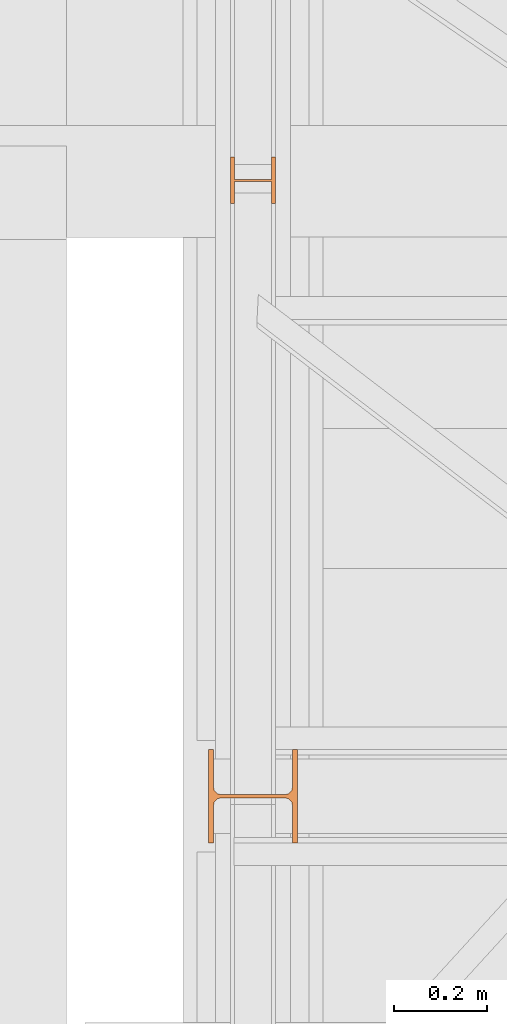
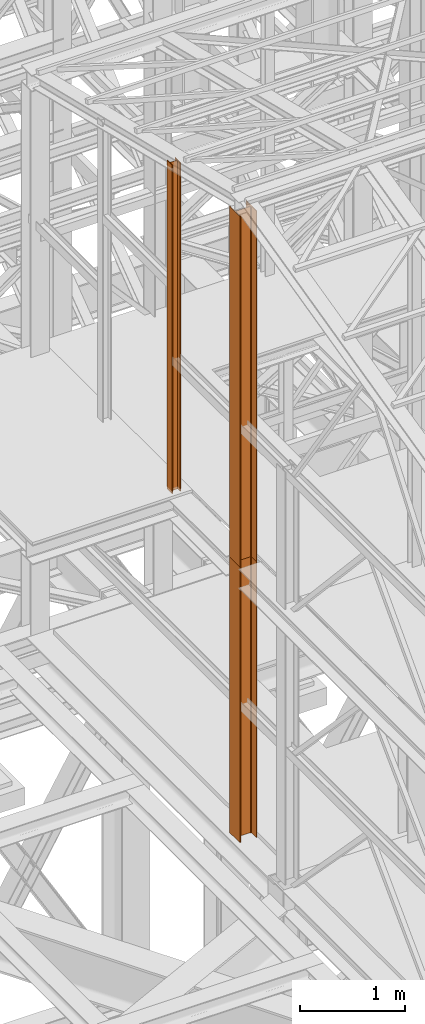
# One storey, part 25 of 208: 4 proxies.
"""IFC2X3 building model written with IfcOpenShell, lengths in millimetres."""

from ifc_helpers import new_model, entity, si_unit, converted_unit, frame, origin, origin_with_axes, place, context, subcontext, project, spatial, faceted_brep, element, save


model = new_model("IFC2X3")

# Units and contexts
model_context = context("Model", 3, precision=1e-05, world=origin())
plan_context = context("Plan", 3, precision=1e-05, world=origin())
body_context = subcontext(model_context, "Body", "Model", "MODEL_VIEW")
ifc_project = project(units=[si_unit("LENGTHUNIT", "METRE", prefix="MILLI"), converted_unit("PLANEANGLEUNIT", "DEGREE", entity("IfcPlaneAngleMeasure", 0.0174532925199433), si_unit("PLANEANGLEUNIT", "RADIAN"), dimensions=[0, 0, 0, 0, 0, 0, 0]), si_unit("AREAUNIT", "SQUARE_METRE"), si_unit("VOLUMEUNIT", "CUBIC_METRE")], contexts=[model_context, plan_context])

# Building, storey
building_placement = place(None, origin())
building = spatial("IfcBuilding", under=ifc_project, at=building_placement, CompositionType="COMPLEX")
storey_placement = place(building_placement, origin_with_axes())
storey = spatial("IfcBuildingStorey", under=building, at=storey_placement, Name="Geschoss", CompositionType="ELEMENT")

# Proxies
proxy_1_placement = place(storey_placement, frame((1150.254968528656, -19946.16159122138, 8484.990002086159), z_axis=(0.0, 0.0, 1.0), x_axis=(1.0, 0.0, 0.0)))
element("IfcBuildingElementProxy", 1, at=proxy_1_placement, inside=storey, context=body_context, shape_type="Brep", body=[
    faceted_brep([(8.009999999999991, 0.00999999999839929, 3814.126443496871), (0.009999999999990905, 0.00999999999839929, 3814.126443496871), (0.009999999999990905, 100.0099999999984, 3814.126443496871), (8.009999999999991, 100.0099999999984, 3814.126443496871), (8.009999999999991, 52.5099999999984, 3814.126443496871), (88.00999999999999, 52.5099999999984, 3814.126443496871), (88.00999999999999, 100.0099999999984, 3814.126443496871), (96.00999999999999, 100.0099999999984, 3814.126443496871), (96.00999999999999, 0.00999999999839929, 3814.126443496871), (88.00999999999999, 0.00999999999839929, 3814.126443496871), (88.00999999999999, 47.5099999999984, 3814.126443496871), (8.009999999999991, 47.5099999999984, 3814.126443496871), (0.009999999999990905, 0.00999999999839929, 3814.126443496871), (8.009999999999991, 0.00999999999839929, 3814.126443496871), (8.009999999999991, 0.00999999999839929, 0.01000000000021828), (0.009999999999990905, 0.00999999999839929, 0.01000000000021828), (0.009999999999990905, 100.0099999999984, 3814.126443496871), (0.009999999999990905, 0.00999999999839929, 3814.126443496871), (0.009999999999990905, 0.00999999999839929, 0.01000000000021828), (0.009999999999990905, 100.0099999999984, 0.01000000000021828), (8.009999999999991, 100.0099999999984, 3814.126443496871), (0.009999999999990905, 100.0099999999984, 3814.126443496871), (0.009999999999990905, 100.0099999999984, 0.01000000000021828), (8.009999999999991, 100.0099999999984, 0.01000000000021828), (8.009999999999991, 52.5099999999984, 3814.126443496871), (8.009999999999991, 100.0099999999984, 3814.126443496871), (8.009999999999991, 100.0099999999984, 0.01000000000021828), (8.009999999999991, 52.5099999999984, 0.01000000000021828), (88.00999999999999, 52.5099999999984, 3814.126443496871), (8.009999999999991, 52.5099999999984, 3814.126443496871), (8.009999999999991, 52.5099999999984, 0.01000000000021828), (88.00999999999999, 52.5099999999984, 0.01000000000021828), (88.00999999999999, 100.0099999999984, 3814.126443496871), (88.00999999999999, 52.5099999999984, 3814.126443496871), (88.00999999999999, 52.5099999999984, 0.01000000000021828), (88.00999999999999, 100.0099999999984, 0.01000000000021828), (96.00999999999999, 100.0099999999984, 3814.126443496871), (88.00999999999999, 100.0099999999984, 3814.126443496871), (88.00999999999999, 100.0099999999984, 0.01000000000021828), (96.00999999999999, 100.0099999999984, 0.01000000000021828), (96.00999999999999, 0.00999999999839929, 3814.126443496871), (96.00999999999999, 100.0099999999984, 3814.126443496871), (96.00999999999999, 100.0099999999984, 0.01000000000021828), (96.00999999999999, 0.00999999999839929, 0.01000000000021828), (88.00999999999999, 0.00999999999839929, 3814.126443496871), (96.00999999999999, 0.00999999999839929, 3814.126443496871), (96.00999999999999, 0.00999999999839929, 0.01000000000021828), (88.00999999999999, 0.00999999999839929, 0.01000000000021828), (88.00999999999999, 47.5099999999984, 3814.126443496871), (88.00999999999999, 0.00999999999839929, 3814.126443496871), (88.00999999999999, 0.00999999999839929, 0.01000000000021828), (88.00999999999999, 47.5099999999984, 0.01000000000021828), (8.009999999999991, 47.5099999999984, 3814.126443496871), (88.00999999999999, 47.5099999999984, 3814.126443496871), (88.00999999999999, 47.5099999999984, 0.01000000000021828), (8.009999999999991, 47.5099999999984, 0.01000000000021828), (8.009999999999991, 0.00999999999839929, 3814.126443496871), (8.009999999999991, 47.5099999999984, 3814.126443496871), (8.009999999999991, 47.5099999999984, 0.01000000000021828), (8.009999999999991, 0.00999999999839929, 0.01000000000021828), (8.009999999999991, 0.00999999999839929, 0.01000000000021828), (8.009999999999991, 47.5099999999984, 0.01000000000021828), (88.00999999999999, 47.5099999999984, 0.01000000000021828), (88.00999999999999, 0.00999999999839929, 0.01000000000021828), (96.00999999999999, 0.00999999999839929, 0.01000000000021828), (96.00999999999999, 100.0099999999984, 0.01000000000021828), (88.00999999999999, 100.0099999999984, 0.01000000000021828), (88.00999999999999, 52.5099999999984, 0.01000000000021828), (8.009999999999991, 52.5099999999984, 0.01000000000021828), (8.009999999999991, 100.0099999999984, 0.01000000000021828), (0.009999999999990905, 100.0099999999984, 0.01000000000021828), (0.009999999999990905, 0.00999999999839929, 0.01000000000021828)], [[[0, 1, 2, 3, 4, 5, 6, 7, 8, 9, 10, 11]], [[12, 13, 14, 15]], [[16, 17, 18, 19]], [[20, 21, 22, 23]], [[24, 25, 26, 27]], [[28, 29, 30, 31]], [[32, 33, 34, 35]], [[36, 37, 38, 39]], [[40, 41, 42, 43]], [[44, 45, 46, 47]], [[48, 49, 50, 51]], [[52, 53, 54, 55]], [[56, 57, 58, 59]], [[60, 61, 62, 63, 64, 65, 66, 67, 68, 69, 70, 71]]], orient=[[False], [False], [False], [False], [False], [False], [False], [False], [False], [False], [False], [False], [False], [False]]),
])
proxy_2_placement = place(storey_placement, frame((1150.254968528656, -19946.16159122138, 8484.990002086159), z_axis=(0.0, 0.0, 1.0), x_axis=(1.0, 0.0, 0.0)))
element("IfcBuildingElementProxy", 2, at=proxy_2_placement, inside=storey, context=body_context, shape_type="Brep", body=[
    faceted_brep([(8.009999999999991, 0.00999999999839929, 3814.126443496871), (0.009999999999990905, 0.00999999999839929, 3814.126443496871), (0.009999999999990905, 100.0099999999984, 3814.126443496871), (8.009999999999991, 100.0099999999984, 3814.126443496871), (8.009999999999991, 52.5099999999984, 3814.126443496871), (88.00999999999999, 52.5099999999984, 3814.126443496871), (88.00999999999999, 100.0099999999984, 3814.126443496871), (96.00999999999999, 100.0099999999984, 3814.126443496871), (96.00999999999999, 0.00999999999839929, 3814.126443496871), (88.00999999999999, 0.00999999999839929, 3814.126443496871), (88.00999999999999, 47.5099999999984, 3814.126443496871), (8.009999999999991, 47.5099999999984, 3814.126443496871), (0.009999999999990905, 0.00999999999839929, 3814.126443496871), (8.009999999999991, 0.00999999999839929, 3814.126443496871), (8.009999999999991, 0.00999999999839929, 0.01000000000021828), (0.009999999999990905, 0.00999999999839929, 0.01000000000021828), (0.009999999999990905, 100.0099999999984, 3814.126443496871), (0.009999999999990905, 0.00999999999839929, 3814.126443496871), (0.009999999999990905, 0.00999999999839929, 0.01000000000021828), (0.009999999999990905, 100.0099999999984, 0.01000000000021828), (8.009999999999991, 100.0099999999984, 3814.126443496871), (0.009999999999990905, 100.0099999999984, 3814.126443496871), (0.009999999999990905, 100.0099999999984, 0.01000000000021828), (8.009999999999991, 100.0099999999984, 0.01000000000021828), (8.009999999999991, 52.5099999999984, 3814.126443496871), (8.009999999999991, 100.0099999999984, 3814.126443496871), (8.009999999999991, 100.0099999999984, 0.01000000000021828), (8.009999999999991, 52.5099999999984, 0.01000000000021828), (88.00999999999999, 52.5099999999984, 3814.126443496871), (8.009999999999991, 52.5099999999984, 3814.126443496871), (8.009999999999991, 52.5099999999984, 0.01000000000021828), (88.00999999999999, 52.5099999999984, 0.01000000000021828), (88.00999999999999, 100.0099999999984, 3814.126443496871), (88.00999999999999, 52.5099999999984, 3814.126443496871), (88.00999999999999, 52.5099999999984, 0.01000000000021828), (88.00999999999999, 100.0099999999984, 0.01000000000021828), (96.00999999999999, 100.0099999999984, 3814.126443496871), (88.00999999999999, 100.0099999999984, 3814.126443496871), (88.00999999999999, 100.0099999999984, 0.01000000000021828), (96.00999999999999, 100.0099999999984, 0.01000000000021828), (96.00999999999999, 0.00999999999839929, 3814.126443496871), (96.00999999999999, 100.0099999999984, 3814.126443496871), (96.00999999999999, 100.0099999999984, 0.01000000000021828), (96.00999999999999, 0.00999999999839929, 0.01000000000021828), (88.00999999999999, 0.00999999999839929, 3814.126443496871), (96.00999999999999, 0.00999999999839929, 3814.126443496871), (96.00999999999999, 0.00999999999839929, 0.01000000000021828), (88.00999999999999, 0.00999999999839929, 0.01000000000021828), (88.00999999999999, 47.5099999999984, 3814.126443496871), (88.00999999999999, 0.00999999999839929, 3814.126443496871), (88.00999999999999, 0.00999999999839929, 0.01000000000021828), (88.00999999999999, 47.5099999999984, 0.01000000000021828), (8.009999999999991, 47.5099999999984, 3814.126443496871), (88.00999999999999, 47.5099999999984, 3814.126443496871), (88.00999999999999, 47.5099999999984, 0.01000000000021828), (8.009999999999991, 47.5099999999984, 0.01000000000021828), (8.009999999999991, 0.00999999999839929, 3814.126443496871), (8.009999999999991, 47.5099999999984, 3814.126443496871), (8.009999999999991, 47.5099999999984, 0.01000000000021828), (8.009999999999991, 0.00999999999839929, 0.01000000000021828), (8.009999999999991, 0.00999999999839929, 0.01000000000021828), (8.009999999999991, 47.5099999999984, 0.01000000000021828), (88.00999999999999, 47.5099999999984, 0.01000000000021828), (88.00999999999999, 0.00999999999839929, 0.01000000000021828), (96.00999999999999, 0.00999999999839929, 0.01000000000021828), (96.00999999999999, 100.0099999999984, 0.01000000000021828), (88.00999999999999, 100.0099999999984, 0.01000000000021828), (88.00999999999999, 52.5099999999984, 0.01000000000021828), (8.009999999999991, 52.5099999999984, 0.01000000000021828), (8.009999999999991, 100.0099999999984, 0.01000000000021828), (0.009999999999990905, 100.0099999999984, 0.01000000000021828), (0.009999999999990905, 0.00999999999839929, 0.01000000000021828)], [[[0, 1, 2, 3, 4, 5, 6, 7, 8, 9, 10, 11]], [[12, 13, 14, 15]], [[16, 17, 18, 19]], [[20, 21, 22, 23]], [[24, 25, 26, 27]], [[28, 29, 30, 31]], [[32, 33, 34, 35]], [[36, 37, 38, 39]], [[40, 41, 42, 43]], [[44, 45, 46, 47]], [[48, 49, 50, 51]], [[52, 53, 54, 55]], [[56, 57, 58, 59]], [[60, 61, 62, 63, 64, 65, 66, 67, 68, 69, 70, 71]]], orient=[[False], [False], [False], [False], [False], [False], [False], [False], [False], [False], [False], [False], [False], [False]]),
])
proxy_3_placement = place(storey_placement, frame((1103.254953595132, -21317.574391808, 5284.990005364416), z_axis=(0.0, 0.0, 1.0), x_axis=(1.0, 0.0, 0.0)))
element("IfcBuildingElementProxy", 3, at=proxy_3_placement, inside=storey, context=body_context, shape_type="Brep", body=[
    faceted_brep([(0.0100000000009004, 0.00999999999839929, 3200.009996721741), (0.0100000000009004, 200.0100029802306, 3200.009996721741), (10.00999791383833, 200.0100029802306, 3200.009996721741), (10.01000536441893, 121.2600035762771, 3200.009996721741), (11.8745504117021, 111.9441915473326, 3200.009996721741), (18.69419349193663, 105.1245498640819, 3200.009996721741), (28.01000458955855, 103.2600015571697, 3200.009996721741), (162.0100153779993, 103.2600015571697, 3200.009996721741), (171.3258264756212, 105.1245498640819, 3200.009996721741), (178.1454695558557, 111.9441915473326, 3200.009996721741), (180.0100146031389, 121.2600035762771, 3200.009996721741), (180.0100146031389, 200.0100029802306, 3200.009996721741), (190.0100125169763, 200.0100029802306, 3200.009996721741), (190.0100125169763, 0.00999999999839929, 3200.009996721741), (180.0100146031389, 0.00999999999839929, 3200.009996721741), (180.0100146031389, 78.75999940395195, 3200.009996721741), (178.1454695558557, 88.07581143289644, 3200.009996721741), (171.3258264756212, 94.89545311614711, 3200.009996721741), (162.0100153779993, 96.7600014230593, 3200.009996721741), (28.01000458955855, 96.7600014230593, 3200.009996721741), (18.69419349193663, 94.89545311614711, 3200.009996721741), (11.8745504117021, 88.07581143289644, 3200.009996721741), (10.01000536441893, 78.75999940395195, 3200.009996721741), (10.00999791383833, 0.00999999999839929, 3200.009996721741), (0.0100000000009004, 200.0100029802306, 3200.009996721741), (0.0100000000009004, 0.00999999999839929, 3200.009996721741), (0.009999999999990905, 0.00999999999839929, 0.009999999999308784), (0.009999999999990905, 200.0100029802306, 0.009999999999308784), (10.00999791383833, 200.0100029802306, 3200.009996721741), (0.0100000000009004, 200.0100029802306, 3200.009996721741), (0.009999999999990905, 200.0100029802306, 0.009999999999308784), (10.00999791383742, 200.0100029802306, 0.009999999999308784), (10.01000536441893, 121.2600035762771, 3200.009996721741), (10.00999791383833, 200.0100029802306, 3200.009996721741), (10.00999791383742, 200.0100029802306, 0.009999999999308784), (10.01000536441802, 121.2600035762771, 0.009999999999308784), (11.8745504117021, 111.9441915473326, 3200.009996721741), (10.01000536441893, 121.2600035762771, 3200.009996721741), (10.01000536441802, 121.2600035762771, 0.009999999999308784), (11.87455041170119, 111.9441915473326, 0.009999999999308784), (18.69419349193663, 105.1245498640819, 3200.009996721741), (11.8745504117021, 111.9441915473326, 3200.009996721741), (11.87455041170119, 111.9441915473326, 0.009999999999308784), (18.69419349193572, 105.1245498640819, 0.009999999999308784), (28.01000458955855, 103.2600015571697, 3200.009996721741), (18.69419349193663, 105.1245498640819, 3200.009996721741), (18.69419349193572, 105.1245498640819, 0.009999999999308784), (28.01000458955764, 103.2600015571697, 0.009999999999308784), (162.0100153779993, 103.2600015571697, 3200.009996721741), (28.01000458955855, 103.2600015571697, 3200.009996721741), (28.01000458955764, 103.2600015571697, 0.009999999999308784), (162.0100153779983, 103.2600015571697, 0.009999999999308784), (171.3258264756212, 105.1245498640819, 3200.009996721741), (162.0100153779993, 103.2600015571697, 3200.009996721741), (162.0100153779983, 103.2600015571697, 0.009999999999308784), (171.3258264756203, 105.1245498640819, 0.009999999999308784), (178.1454695558557, 111.9441915473326, 3200.009996721741), (171.3258264756212, 105.1245498640819, 3200.009996721741), (171.3258264756203, 105.1245498640819, 0.009999999999308784), (178.1454695558548, 111.9441915473326, 0.009999999999308784), (180.0100146031389, 121.2600035762771, 3200.009996721741), (178.1454695558557, 111.9441915473326, 3200.009996721741), (178.1454695558548, 111.9441915473326, 0.009999999999308784), (180.010014603138, 121.2600035762771, 0.009999999999308784), (180.0100146031389, 200.0100029802306, 3200.009996721741), (180.0100146031389, 121.2600035762771, 3200.009996721741), (180.010014603138, 121.2600035762771, 0.009999999999308784), (180.010014603138, 200.0100029802306, 0.009999999999308784), (190.0100125169763, 200.0100029802306, 3200.009996721741), (180.0100146031389, 200.0100029802306, 3200.009996721741), (180.010014603138, 200.0100029802306, 0.009999999999308784), (190.0100125169754, 200.0100029802306, 0.009999999999308784), (190.0100125169763, 0.00999999999839929, 3200.009996721741), (190.0100125169763, 200.0100029802306, 3200.009996721741), (190.0100125169754, 200.0100029802306, 0.009999999999308784), (190.0100125169754, 0.00999999999839929, 0.009999999999308784), (180.0100146031389, 0.00999999999839929, 3200.009996721741), (190.0100125169763, 0.00999999999839929, 3200.009996721741), (190.0100125169754, 0.00999999999839929, 0.009999999999308784), (180.010014603138, 0.00999999999839929, 0.009999999999308784), (180.0100146031389, 78.75999940395195, 3200.009996721741), (180.0100146031389, 0.00999999999839929, 3200.009996721741), (180.010014603138, 0.00999999999839929, 0.009999999999308784), (180.010014603138, 78.75999940395195, 0.009999999999308784), (178.1454695558557, 88.07581143289644, 3200.009996721741), (180.0100146031389, 78.75999940395195, 3200.009996721741), (180.010014603138, 78.75999940395195, 0.009999999999308784), (178.1454695558548, 88.07581143289644, 0.009999999999308784), (171.3258264756212, 94.89545311614711, 3200.009996721741), (178.1454695558557, 88.07581143289644, 3200.009996721741), (178.1454695558548, 88.07581143289644, 0.009999999999308784), (171.3258264756203, 94.89545311614711, 0.009999999999308784), (162.0100153779993, 96.7600014230593, 3200.009996721741), (171.3258264756212, 94.89545311614711, 3200.009996721741), (171.3258264756203, 94.89545311614711, 0.009999999999308784), (162.0100153779983, 96.7600014230593, 0.009999999999308784), (28.01000458955855, 96.7600014230593, 3200.009996721741), (162.0100153779993, 96.7600014230593, 3200.009996721741), (162.0100153779983, 96.7600014230593, 0.009999999999308784), (28.01000458955764, 96.7600014230593, 0.009999999999308784), (18.69419349193663, 94.89545311614711, 3200.009996721741), (28.01000458955855, 96.7600014230593, 3200.009996721741), (28.01000458955764, 96.7600014230593, 0.009999999999308784), (18.69419349193572, 94.89545311614711, 0.009999999999308784), (11.8745504117021, 88.07581143289644, 3200.009996721741), (18.69419349193663, 94.89545311614711, 3200.009996721741), (18.69419349193572, 94.89545311614711, 0.009999999999308784), (11.87455041170119, 88.07581143289644, 0.009999999999308784), (10.01000536441893, 78.75999940395195, 3200.009996721741), (11.8745504117021, 88.07581143289644, 3200.009996721741), (11.87455041170119, 88.07581143289644, 0.009999999999308784), (10.01000536441802, 78.75999940395195, 0.009999999999308784), (10.00999791383833, 0.00999999999839929, 3200.009996721741), (10.01000536441893, 78.75999940395195, 3200.009996721741), (10.01000536441802, 78.75999940395195, 0.009999999999308784), (10.00999791383742, 0.00999999999839929, 0.009999999999308784), (0.0100000000009004, 0.00999999999839929, 3200.009996721741), (10.00999791383833, 0.00999999999839929, 3200.009996721741), (10.00999791383742, 0.00999999999839929, 0.009999999999308784), (0.009999999999990905, 0.00999999999839929, 0.009999999999308784), (0.009999999999990905, 0.00999999999839929, 0.009999999999308784), (10.00999791383742, 0.00999999999839929, 0.009999999999308784), (10.01000536441802, 78.75999940395195, 0.009999999999308784), (11.87455041170119, 88.07581143289644, 0.009999999999308784), (18.69419349193572, 94.89545311614711, 0.009999999999308784), (28.01000458955764, 96.7600014230593, 0.009999999999308784), (162.0100153779983, 96.7600014230593, 0.009999999999308784), (171.3258264756203, 94.89545311614711, 0.009999999999308784), (178.1454695558548, 88.07581143289644, 0.009999999999308784), (180.010014603138, 78.75999940395195, 0.009999999999308784), (180.010014603138, 0.00999999999839929, 0.009999999999308784), (190.0100125169754, 0.00999999999839929, 0.009999999999308784), (190.0100125169754, 200.0100029802306, 0.009999999999308784), (180.010014603138, 200.0100029802306, 0.009999999999308784), (180.010014603138, 121.2600035762771, 0.009999999999308784), (178.1454695558548, 111.9441915473326, 0.009999999999308784), (171.3258264756203, 105.1245498640819, 0.009999999999308784), (162.0100153779983, 103.2600015571697, 0.009999999999308784), (28.01000458955764, 103.2600015571697, 0.009999999999308784), (18.69419349193572, 105.1245498640819, 0.009999999999308784), (11.87455041170119, 111.9441915473326, 0.009999999999308784), (10.01000536441802, 121.2600035762771, 0.009999999999308784), (10.00999791383742, 200.0100029802306, 0.009999999999308784), (0.009999999999990905, 200.0100029802306, 0.009999999999308784)], [[[0, 1, 2, 3, 4, 5, 6, 7, 8, 9, 10, 11, 12, 13, 14, 15, 16, 17, 18, 19, 20, 21, 22, 23]], [[24, 25, 26, 27]], [[28, 29, 30, 31]], [[32, 33, 34, 35]], [[36, 37, 38, 39]], [[40, 41, 42, 43]], [[44, 45, 46, 47]], [[48, 49, 50, 51]], [[52, 53, 54, 55]], [[56, 57, 58, 59]], [[60, 61, 62, 63]], [[64, 65, 66, 67]], [[68, 69, 70, 71]], [[72, 73, 74, 75]], [[76, 77, 78, 79]], [[80, 81, 82, 83]], [[84, 85, 86, 87]], [[88, 89, 90, 91]], [[92, 93, 94, 95]], [[96, 97, 98, 99]], [[100, 101, 102, 103]], [[104, 105, 106, 107]], [[108, 109, 110, 111]], [[112, 113, 114, 115]], [[116, 117, 118, 119]], [[120, 121, 122, 123, 124, 125, 126, 127, 128, 129, 130, 131, 132, 133, 134, 135, 136, 137, 138, 139, 140, 141, 142, 143]]], orient=[[False], [False], [False], [False], [False], [False], [False], [False], [False], [False], [False], [False], [False], [False], [False], [False], [False], [False], [False], [False], [False], [False], [False], [False], [False], [False]]),
])
proxy_4_placement = place(storey_placement, frame((1103.25496227017, -21317.57439178015, 8484.990002086157), z_axis=(0.0, 0.0, 1.0), x_axis=(1.0, 0.0, 0.0)))
element("IfcBuildingElementProxy", 4, at=proxy_4_placement, inside=storey, context=body_context, shape_type="Brep", body=[
    faceted_brep([(0.009999999999990905, 0.01000864719753736, 4065.914535727219), (0.009999999999990905, 200.0100116274298, 4065.914535727219), (10.00999791383742, 200.0100116274298, 4065.914535727219), (10.01000536441802, 121.2600122234762, 4065.914535727219), (11.87455041170119, 111.9442001945317, 4065.914535727219), (18.69419349193572, 105.1245585112811, 4065.914535727219), (28.01000458955764, 103.2600102043689, 4065.914535727219), (162.0100153779983, 103.2600102043689, 4065.914535727219), (171.3258264756203, 105.1245585112811, 4065.914535727219), (178.1454695558548, 111.9442001945317, 4065.914535727219), (180.010014603138, 121.2600122234762, 4065.914535727219), (180.010014603138, 200.0100116274298, 4065.914535727219), (190.0100125169754, 200.0100116274298, 4065.914535727219), (190.0100125169754, 0.01000864719753736, 4065.914535727219), (180.010014603138, 0.01000864719753736, 4065.914535727219), (180.010014603138, 78.76000805115109, 4065.914535727219), (178.1454695558548, 88.07582008009558, 4065.914535727219), (171.3258264756203, 94.89546176334625, 4065.914535727219), (162.0100153779983, 96.76001007025843, 4065.914535727219), (28.01000458955764, 96.76001007025843, 4065.914535727219), (18.69419349193572, 94.89546176334625, 4065.914535727219), (11.87455041170119, 88.07582008009558, 4065.914535727219), (10.01000536441802, 78.76000805115109, 4065.914535727219), (10.00999791383742, 0.01000864719753736, 4065.914535727219), (0.009999999999990905, 200.0100116274298, 4065.914535727219), (0.009999999999990905, 0.01000864719753736, 4065.914535727219), (0.009999999999990905, 0.01000000000203727, 0.01000000000021828), (0.009999999999990905, 200.0100029802343, 0.01000000000021828), (10.00999791383742, 200.0100116274298, 4065.914535727219), (0.009999999999990905, 200.0100116274298, 4065.914535727219), (0.009999999999990905, 200.0100029802343, 0.01000000000021828), (10.00999791383742, 200.0100029802343, 0.01000000000021828), (10.01000536441802, 121.2600122234762, 4065.914535727219), (10.00999791383742, 200.0100116274298, 4065.914535727219), (10.00999791383742, 200.0100029802343, 0.01000000000021828), (10.01000536441802, 121.2600035762807, 0.01000000000021828), (11.87455041170119, 111.9442001945317, 4065.914535727219), (10.01000536441802, 121.2600122234762, 4065.914535727219), (10.01000536441802, 121.2600035762807, 0.01000000000021828), (11.87455041170119, 111.9441915473362, 0.01000000000021828), (18.69419349193572, 105.1245585112811, 4065.914535727219), (11.87455041170119, 111.9442001945317, 4065.914535727219), (11.87455041170119, 111.9441915473362, 0.01000000000021828), (18.69419349193572, 105.1245498640856, 0.01000000000021828), (28.01000458955764, 103.2600102043689, 4065.914535727219), (18.69419349193572, 105.1245585112811, 4065.914535727219), (18.69419349193572, 105.1245498640856, 0.01000000000021828), (28.01000458955764, 103.2600015571734, 0.01000000000021828), (162.0100153779983, 103.2600102043689, 4065.914535727219), (28.01000458955764, 103.2600102043689, 4065.914535727219), (28.01000458955764, 103.2600015571734, 0.01000000000021828), (162.0100153779983, 103.2600015571734, 0.01000000000021828), (171.3258264756203, 105.1245585112811, 4065.914535727219), (162.0100153779983, 103.2600102043689, 4065.914535727219), (162.0100153779983, 103.2600015571734, 0.01000000000021828), (171.3258264756203, 105.1245498640856, 0.01000000000021828), (178.1454695558548, 111.9442001945317, 4065.914535727219), (171.3258264756203, 105.1245585112811, 4065.914535727219), (171.3258264756203, 105.1245498640856, 0.01000000000021828), (178.1454695558548, 111.9441915473362, 0.01000000000021828), (180.010014603138, 121.2600122234762, 4065.914535727219), (178.1454695558548, 111.9442001945317, 4065.914535727219), (178.1454695558548, 111.9441915473362, 0.01000000000021828), (180.010014603138, 121.2600035762807, 0.01000000000021828), (180.010014603138, 200.0100116274298, 4065.914535727219), (180.010014603138, 121.2600122234762, 4065.914535727219), (180.010014603138, 121.2600035762807, 0.01000000000021828), (180.010014603138, 200.0100029802343, 0.01000000000021828), (190.0100125169754, 200.0100116274298, 4065.914535727219), (180.010014603138, 200.0100116274298, 4065.914535727219), (180.010014603138, 200.0100029802343, 0.01000000000021828), (190.0100125169754, 200.0100029802343, 0.01000000000021828), (190.0100125169754, 0.01000864719753736, 4065.914535727219), (190.0100125169754, 200.0100116274298, 4065.914535727219), (190.0100125169754, 200.0100029802343, 0.01000000000021828), (190.0100125169754, 0.01000000000203727, 0.01000000000021828), (180.010014603138, 0.01000864719753736, 4065.914535727219), (190.0100125169754, 0.01000864719753736, 4065.914535727219), (190.0100125169754, 0.01000000000203727, 0.01000000000021828), (180.010014603138, 0.01000000000203727, 0.01000000000021828), (180.010014603138, 78.76000805115109, 4065.914535727219), (180.010014603138, 0.01000864719753736, 4065.914535727219), (180.010014603138, 0.01000000000203727, 0.01000000000021828), (180.010014603138, 78.75999940395559, 0.01000000000021828), (178.1454695558548, 88.07582008009558, 4065.914535727219), (180.010014603138, 78.76000805115109, 4065.914535727219), (180.010014603138, 78.75999940395559, 0.01000000000021828), (178.1454695558548, 88.07581143290008, 0.01000000000021828), (171.3258264756203, 94.89546176334625, 4065.914535727219), (178.1454695558548, 88.07582008009558, 4065.914535727219), (178.1454695558548, 88.07581143290008, 0.01000000000021828), (171.3258264756203, 94.89545311615075, 0.01000000000021828), (162.0100153779983, 96.76001007025843, 4065.914535727219), (171.3258264756203, 94.89546176334625, 4065.914535727219), (171.3258264756203, 94.89545311615075, 0.01000000000021828), (162.0100153779983, 96.76000142306293, 0.01000000000021828), (28.01000458955764, 96.76001007025843, 4065.914535727219), (162.0100153779983, 96.76001007025843, 4065.914535727219), (162.0100153779983, 96.76000142306293, 0.01000000000021828), (28.01000458955764, 96.76000142306293, 0.01000000000021828), (18.69419349193572, 94.89546176334625, 4065.914535727219), (28.01000458955764, 96.76001007025843, 4065.914535727219), (28.01000458955764, 96.76000142306293, 0.01000000000021828), (18.69419349193572, 94.89545311615075, 0.01000000000021828), (11.87455041170119, 88.07582008009558, 4065.914535727219), (18.69419349193572, 94.89546176334625, 4065.914535727219), (18.69419349193572, 94.89545311615075, 0.01000000000021828), (11.87455041170119, 88.07581143290008, 0.01000000000021828), (10.01000536441802, 78.76000805115109, 4065.914535727219), (11.87455041170119, 88.07582008009558, 4065.914535727219), (11.87455041170119, 88.07581143290008, 0.01000000000021828), (10.01000536441802, 78.75999940395559, 0.01000000000021828), (10.00999791383742, 0.01000864719753736, 4065.914535727219), (10.01000536441802, 78.76000805115109, 4065.914535727219), (10.01000536441802, 78.75999940395559, 0.01000000000021828), (10.00999791383742, 0.01000000000203727, 0.01000000000021828), (0.009999999999990905, 0.01000864719753736, 4065.914535727219), (10.00999791383742, 0.01000864719753736, 4065.914535727219), (10.00999791383742, 0.01000000000203727, 0.01000000000021828), (0.009999999999990905, 0.01000000000203727, 0.01000000000021828), (0.009999999999990905, 0.01000000000203727, 0.01000000000021828), (10.00999791383742, 0.01000000000203727, 0.01000000000021828), (10.01000536441802, 78.75999940395559, 0.01000000000021828), (11.87455041170119, 88.07581143290008, 0.01000000000021828), (18.69419349193572, 94.89545311615075, 0.01000000000021828), (28.01000458955764, 96.76000142306293, 0.01000000000021828), (162.0100153779983, 96.76000142306293, 0.01000000000021828), (171.3258264756203, 94.89545311615075, 0.01000000000021828), (178.1454695558548, 88.07581143290008, 0.01000000000021828), (180.010014603138, 78.75999940395559, 0.01000000000021828), (180.010014603138, 0.01000000000203727, 0.01000000000021828), (190.0100125169754, 0.01000000000203727, 0.01000000000021828), (190.0100125169754, 200.0100029802343, 0.01000000000021828), (180.010014603138, 200.0100029802343, 0.01000000000021828), (180.010014603138, 121.2600035762807, 0.01000000000021828), (178.1454695558548, 111.9441915473362, 0.01000000000021828), (171.3258264756203, 105.1245498640856, 0.01000000000021828), (162.0100153779983, 103.2600015571734, 0.01000000000021828), (28.01000458955764, 103.2600015571734, 0.01000000000021828), (18.69419349193572, 105.1245498640856, 0.01000000000021828), (11.87455041170119, 111.9441915473362, 0.01000000000021828), (10.01000536441802, 121.2600035762807, 0.01000000000021828), (10.00999791383742, 200.0100029802343, 0.01000000000021828), (0.009999999999990905, 200.0100029802343, 0.01000000000021828)], [[[0, 1, 2, 3, 4, 5, 6, 7, 8, 9, 10, 11, 12, 13, 14, 15, 16, 17, 18, 19, 20, 21, 22, 23]], [[24, 25, 26, 27]], [[28, 29, 30, 31]], [[32, 33, 34, 35]], [[36, 37, 38, 39]], [[40, 41, 42, 43]], [[44, 45, 46, 47]], [[48, 49, 50, 51]], [[52, 53, 54, 55]], [[56, 57, 58, 59]], [[60, 61, 62, 63]], [[64, 65, 66, 67]], [[68, 69, 70, 71]], [[72, 73, 74, 75]], [[76, 77, 78, 79]], [[80, 81, 82, 83]], [[84, 85, 86, 87]], [[88, 89, 90, 91]], [[92, 93, 94, 95]], [[96, 97, 98, 99]], [[100, 101, 102, 103]], [[104, 105, 106, 107]], [[108, 109, 110, 111]], [[112, 113, 114, 115]], [[116, 117, 118, 119]], [[120, 121, 122, 123, 124, 125, 126, 127, 128, 129, 130, 131, 132, 133, 134, 135, 136, 137, 138, 139, 140, 141, 142, 143]]], orient=[[False], [False], [False], [False], [False], [False], [False], [False], [False], [False], [False], [False], [False], [False], [False], [False], [False], [False], [False], [False], [False], [False], [False], [False], [False], [False]]),
])

save(model, "model.ifc")
